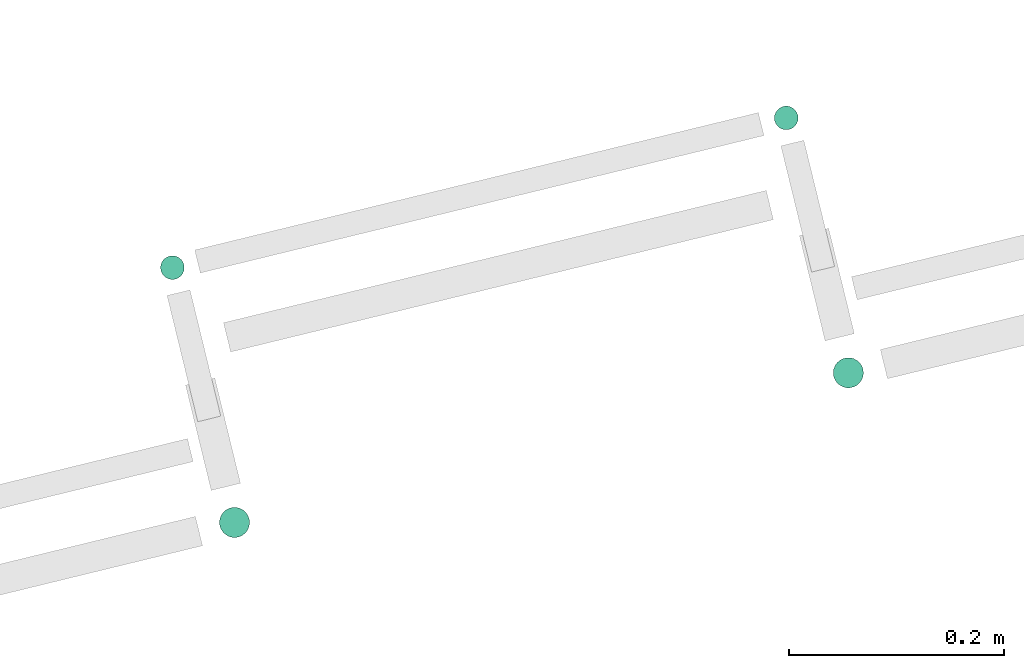
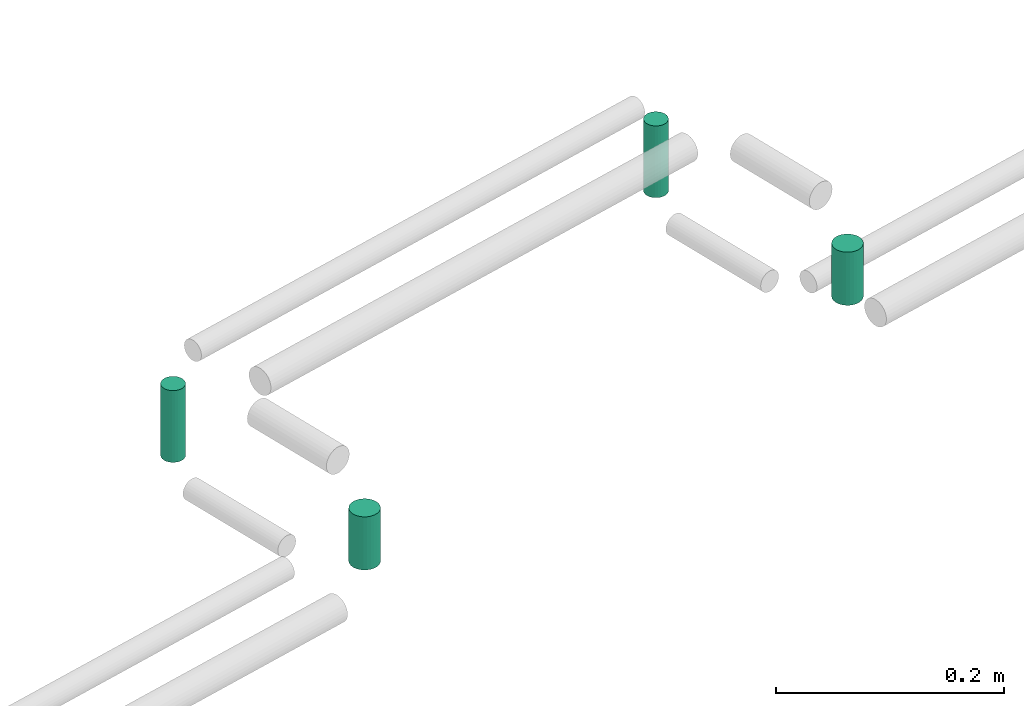
# One storey, part 248 of 331: 4 flow segments.
"""IFC2X3 building model written with IfcOpenShell, lengths in millimetres."""

from ifc_helpers import new_model, entity, si_unit, converted_unit, derived_unit, direction, frame, origin, origin_2d_with_axis, place, context, subcontext, project, spatial, circle, extrude, type_object, element, save


model = new_model("IFC2X3")

# Units and contexts
model_context = context("Model", 3, precision=0.01, world=origin(), true_north=direction((6.12303176911189e-17, 1.0)))
body_context = subcontext(model_context, "Body", "Model", "MODEL_VIEW")
ifc_project = project(units=[si_unit("LENGTHUNIT", "METRE", prefix="MILLI"), si_unit("AREAUNIT", "SQUARE_METRE"), si_unit("VOLUMEUNIT", "CUBIC_METRE"), converted_unit("PLANEANGLEUNIT", "DEGREE", entity("IfcRatioMeasure", 0.0174532925199433), si_unit("PLANEANGLEUNIT", "RADIAN"), dimensions=[0, 0, 0, 0, 0, 0, 0]), si_unit("MASSUNIT", "GRAM", prefix="KILO"), derived_unit("MASSDENSITYUNIT", [(si_unit("MASSUNIT", "GRAM", prefix="KILO"), 1), (si_unit("LENGTHUNIT", "METRE"), -3)]), derived_unit("MOMENTOFINERTIAUNIT", [(si_unit("LENGTHUNIT", "METRE"), 4)]), si_unit("TIMEUNIT", "SECOND"), si_unit("FREQUENCYUNIT", "HERTZ"), si_unit("THERMODYNAMICTEMPERATUREUNIT", "DEGREE_CELSIUS"), derived_unit("THERMALTRANSMITTANCEUNIT", [(si_unit("MASSUNIT", "GRAM", prefix="KILO"), 1), (si_unit("THERMODYNAMICTEMPERATUREUNIT", "KELVIN"), -1), (si_unit("TIMEUNIT", "SECOND"), -3)]), derived_unit("VOLUMETRICFLOWRATEUNIT", [(si_unit("LENGTHUNIT", "METRE"), 3), (si_unit("TIMEUNIT", "SECOND"), -1)]), derived_unit("MASSFLOWRATEUNIT", [(si_unit("MASSUNIT", "GRAM", prefix="KILO"), 1), (si_unit("TIMEUNIT", "SECOND"), -1)]), derived_unit("ROTATIONALFREQUENCYUNIT", [(si_unit("TIMEUNIT", "SECOND"), -1)]), si_unit("ELECTRICCURRENTUNIT", "AMPERE"), si_unit("ELECTRICVOLTAGEUNIT", "VOLT"), si_unit("POWERUNIT", "WATT"), si_unit("FORCEUNIT", "NEWTON", prefix="KILO"), si_unit("ILLUMINANCEUNIT", "LUX"), si_unit("LUMINOUSFLUXUNIT", "LUMEN"), si_unit("LUMINOUSINTENSITYUNIT", "CANDELA"), derived_unit("USERDEFINED", [(si_unit("MASSUNIT", "GRAM", prefix="KILO"), -1), (si_unit("LENGTHUNIT", "METRE"), -2), (si_unit("TIMEUNIT", "SECOND"), 3), (si_unit("LUMINOUSFLUXUNIT", "LUMEN"), 1)]), derived_unit("LINEARVELOCITYUNIT", [(si_unit("LENGTHUNIT", "METRE"), 1), (si_unit("TIMEUNIT", "SECOND"), -1)]), si_unit("PRESSUREUNIT", "PASCAL"), derived_unit("USERDEFINED", [(si_unit("LENGTHUNIT", "METRE"), -2), (si_unit("MASSUNIT", "GRAM", prefix="KILO"), 1), (si_unit("TIMEUNIT", "SECOND"), -2)]), derived_unit("LINEARFORCEUNIT", [(si_unit("MASSUNIT", "GRAM", prefix="KILO"), 1), (si_unit("LENGTHUNIT", "METRE"), 1), (si_unit("TIMEUNIT", "SECOND"), -2), (si_unit("LENGTHUNIT", "METRE"), -1)]), derived_unit("PLANARFORCEUNIT", [(si_unit("MASSUNIT", "GRAM", prefix="KILO"), 1), (si_unit("LENGTHUNIT", "METRE"), 1), (si_unit("TIMEUNIT", "SECOND"), -2), (si_unit("LENGTHUNIT", "METRE"), -2)])], contexts=[model_context])

# Site, building, storey
site_placement = place(None, frame((0.0, -0.00077364408347762, 0.0)))
site = spatial("IfcSite", under=ifc_project, at=site_placement, CompositionType="ELEMENT")
building_placement = place(site_placement, origin())
building = spatial("IfcBuilding", under=site, at=building_placement, CompositionType="ELEMENT")
storey_placement = place(building_placement, origin())
storey = spatial("IfcBuildingStorey", under=building, at=storey_placement, CompositionType="ELEMENT", Elevation=0.0)

# Flow segments
pipe_segment_type = type_object("IfcPipeSegmentType", PredefinedType="NOTDEFINED")
flow_segment_1_placement = place(building_placement, frame((-17253.3874084645, 10672.0845192831, 2659.0)))
element("IfcFlowSegment", 1, at=flow_segment_1_placement, inside=storey, type_object=pipe_segment_type, context=body_context, shape_type="SweptSolid", body=[
    extrude(circle(Radius=14.0, at=origin_2d_with_axis()), frame((15.5952722359149, 15.5952722359149, 0.0)), (0.0, 0.0, 1.0), 57.0000000000038),
])
flow_segment_2_placement = place(building_placement, frame((-17823.7784296232, 10533.0490047645, 2659.0)))
element("IfcFlowSegment", 2, at=flow_segment_2_placement, inside=storey, type_object=pipe_segment_type, context=body_context, shape_type="SweptSolid", body=[
    extrude(circle(Radius=14.0, at=origin_2d_with_axis()), frame((15.5952722359149, 15.5952722359149, 0.0), z_axis=(0.0, 0.0, 1.0), x_axis=(-1.0, 0.0, 0.0)), (0.0, 0.0, 1.0), 57.0000000000119),
])
flow_segment_3_placement = place(building_placement, frame((-17878.4942726066, 10772.8273468328, 2649.0)))
element("IfcFlowSegment", 3, at=flow_segment_3_placement, inside=storey, type_object=pipe_segment_type, context=body_context, shape_type="SweptSolid", body=[
    extrude(circle(Radius=11.0, at=origin_2d_with_axis()), frame((12.5952722359156, 12.5952722359156, 0.0)), (0.0, 0.0, 1.0), 77.0000000000188),
])
flow_segment_4_placement = place(building_placement, frame((-17308.1032514478, 10911.8628613514, 2649.0)))
element("IfcFlowSegment", 4, at=flow_segment_4_placement, inside=storey, type_object=pipe_segment_type, context=body_context, shape_type="SweptSolid", body=[
    extrude(circle(Radius=11.0, at=origin_2d_with_axis()), frame((12.5952722359156, 12.5952722359156, 0.0)), (0.0, 0.0, 1.0), 77.0000000000117),
])

save(model, "model.ifc")
